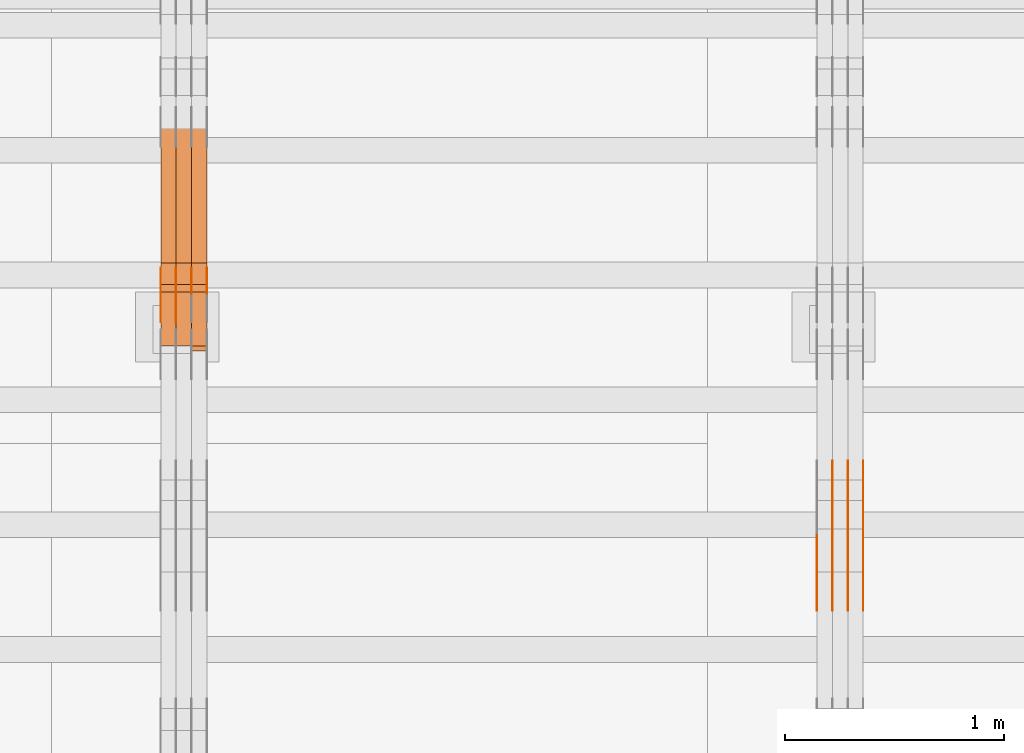
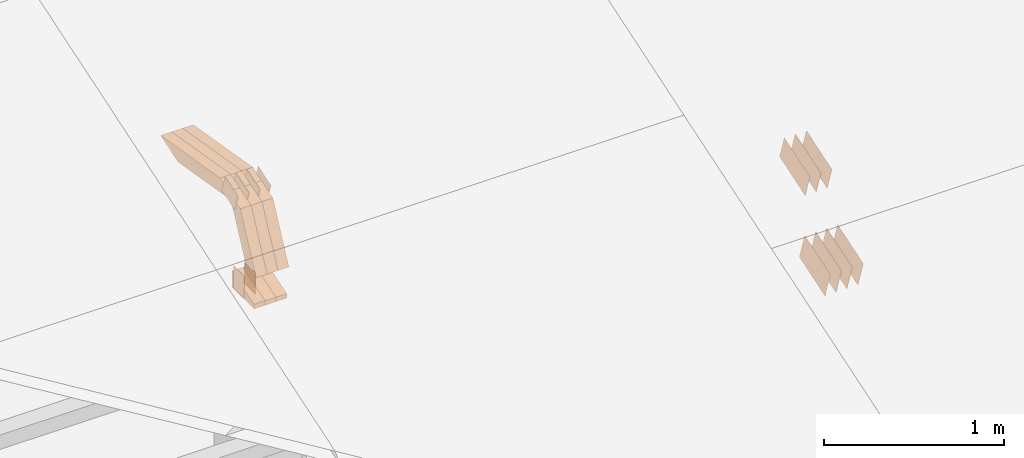
# One storey, part 94 of 385: 28 proxies.
"""IFC2X3 building model written with IfcOpenShell, lengths in millimetres."""

from ifc_helpers import new_model, entity, si_unit, converted_unit, derived_unit, direction, frame, frame_2d, origin, place, context, subcontext, project, spatial, polyline, rectangle, outline, extrude, source, transform, mapped, material, type_object, type_shapes, element, save


model = new_model("IFC2X3")

# Units and contexts
model_context = context("Model", 3, precision=0.01, world=origin(), true_north=direction((6.12303176911189e-17, 1.0)))
body_context = subcontext(model_context, "Body", "Model", "MODEL_VIEW")
ifc_project = project(units=[si_unit("LENGTHUNIT", "METRE", prefix="MILLI"), si_unit("AREAUNIT", "SQUARE_METRE"), si_unit("VOLUMEUNIT", "CUBIC_METRE"), converted_unit("PLANEANGLEUNIT", "DEGREE", entity("IfcRatioMeasure", 0.0174532925199433), si_unit("PLANEANGLEUNIT", "RADIAN"), dimensions=[0, 0, 0, 0, 0, 0, 0]), si_unit("MASSUNIT", "GRAM", prefix="KILO"), derived_unit("MASSDENSITYUNIT", [(si_unit("MASSUNIT", "GRAM", prefix="KILO"), 1), (si_unit("LENGTHUNIT", "METRE"), -3)]), si_unit("TIMEUNIT", "SECOND"), si_unit("FREQUENCYUNIT", "HERTZ"), si_unit("THERMODYNAMICTEMPERATUREUNIT", "DEGREE_CELSIUS"), derived_unit("THERMALTRANSMITTANCEUNIT", [(si_unit("MASSUNIT", "GRAM", prefix="KILO"), 1), (si_unit("THERMODYNAMICTEMPERATUREUNIT", "KELVIN"), -1), (si_unit("TIMEUNIT", "SECOND"), -3)]), derived_unit("VOLUMETRICFLOWRATEUNIT", [(si_unit("LENGTHUNIT", "METRE"), 3), (si_unit("TIMEUNIT", "SECOND"), -1)]), si_unit("ELECTRICCURRENTUNIT", "AMPERE"), si_unit("ELECTRICVOLTAGEUNIT", "VOLT"), si_unit("POWERUNIT", "WATT"), si_unit("FORCEUNIT", "NEWTON", prefix="KILO"), si_unit("ILLUMINANCEUNIT", "LUX"), si_unit("LUMINOUSFLUXUNIT", "LUMEN"), si_unit("LUMINOUSINTENSITYUNIT", "CANDELA"), derived_unit("USERDEFINED", [(si_unit("MASSUNIT", "GRAM", prefix="KILO"), -1), (si_unit("LENGTHUNIT", "METRE"), -2), (si_unit("TIMEUNIT", "SECOND"), 3), (si_unit("LUMINOUSFLUXUNIT", "LUMEN"), 1)]), derived_unit("LINEARVELOCITYUNIT", [(si_unit("LENGTHUNIT", "METRE"), 1), (si_unit("TIMEUNIT", "SECOND"), -1)]), si_unit("PRESSUREUNIT", "PASCAL"), derived_unit("USERDEFINED", [(si_unit("LENGTHUNIT", "METRE"), -2), (si_unit("MASSUNIT", "GRAM", prefix="KILO"), 1), (si_unit("TIMEUNIT", "SECOND"), -2)])], contexts=[model_context])

# Site, building, storey
site_placement = place(None, origin())
site = spatial("IfcSite", under=ifc_project, at=site_placement, CompositionType="ELEMENT")
building_placement = place(site_placement, origin())
building = spatial("IfcBuilding", under=site, at=building_placement, CompositionType="ELEMENT")
storey_placement = place(building_placement, origin())
storey = spatial("IfcBuildingStorey", under=building, at=storey_placement, Name="Default", CompositionType="ELEMENT", Elevation=0.0)

# Proxies
ifc_material_1 = material(Name="IfcSurfaceStyle #208456")
building_element_proxy_type_1 = type_object("IfcBuildingElementProxyType", PredefinedType="NOTDEFINED", material=ifc_material_1)
shared_shape_1 = source(origin(), body_context, "Body", "SweptSolid", [
    extrude(outline(polyline([(-149.99966632326, -95.9999759039407), (149.999881095801, -95.9999759039407), (150.000557367591, 95.9999759039407), (-150.000772140132, 95.9999759039406), (-149.99966632326, -95.9999759039407)])), frame((150.000557367591, 96.0004291135906, 0.0), z_axis=(0.0, 0.0, 1.0), x_axis=(-1.0, 0.0, 0.0)), (0.0, 0.0, 1.0), 1.29999999999999),
])
type_shapes(building_element_proxy_type_1, [shared_shape_1])
proxy_1_placement = place(building_placement, frame((15386.3, 10934.7734375, 2766.8759765625), z_axis=(-1.0, 0.0, 0.0), x_axis=(0.0, 0.951056516295124, 0.309016994375039)))
element("IfcBuildingElementProxy", 1, at=proxy_1_placement, inside=storey, type_object=building_element_proxy_type_1, material=ifc_material_1, context=body_context, shape_type="MappedRepresentation", body=[
    mapped(shared_shape_1, transform((0.0, 0.0, 0.0), scale=1.0)),
])
ifc_material_2 = material(Name="IfcSurfaceStyle #208399")
building_element_proxy_type_2 = type_object("IfcBuildingElementProxyType", PredefinedType="NOTDEFINED", material=ifc_material_2)
shared_shape_2 = source(origin(), body_context, "Body", "SweptSolid", [
    extrude(outline(polyline([(-149.99966632326, -95.9999759039407), (149.999881095801, -95.9999759039407), (150.000557367591, 95.9999759039407), (-150.000772140132, 95.9999759039406), (-149.99966632326, -95.9999759039407)])), frame((150.000557367591, 96.0004291135906, 0.0), z_axis=(0.0, 0.0, 1.0), x_axis=(-1.0, 0.0, 0.0)), (0.0, 0.0, 1.0), 1.29999999999999),
])
type_shapes(building_element_proxy_type_2, [shared_shape_2])
proxy_2_placement = place(building_placement, frame((15315.0, 10934.7734375, 2766.8759765625), z_axis=(-1.0, 0.0, 0.0), x_axis=(0.0, 0.951056516295124, 0.309016994375039)))
element("IfcBuildingElementProxy", 2, at=proxy_2_placement, inside=storey, type_object=building_element_proxy_type_2, material=ifc_material_2, context=body_context, shape_type="MappedRepresentation", body=[
    mapped(shared_shape_2, transform((0.0, 0.0, 0.0), scale=1.0)),
])
ifc_material_3 = material(Name="IfcSurfaceStyle #208342")
building_element_proxy_type_3 = type_object("IfcBuildingElementProxyType", PredefinedType="NOTDEFINED", material=ifc_material_3)
shared_shape_3 = source(origin(), body_context, "Body", "SweptSolid", [
    extrude(outline(polyline([(-149.99966632326, -95.9999759039407), (149.999881095801, -95.9999759039407), (150.000557367591, 95.9999759039407), (-150.000772140132, 95.9999759039406), (-149.99966632326, -95.9999759039407)])), frame((150.000557367591, 96.0004291135906, 0.0), z_axis=(0.0, 0.0, 1.0), x_axis=(-1.0, 0.0, 0.0)), (0.0, 0.0, 1.0), 1.29999999999999),
])
type_shapes(building_element_proxy_type_3, [shared_shape_3])
proxy_3_placement = place(building_placement, frame((15316.3, 10934.7734375, 2766.8759765625), z_axis=(-1.0, 0.0, 0.0), x_axis=(0.0, 0.951056516295124, 0.309016994375039)))
element("IfcBuildingElementProxy", 3, at=proxy_3_placement, inside=storey, type_object=building_element_proxy_type_3, material=ifc_material_3, context=body_context, shape_type="MappedRepresentation", body=[
    mapped(shared_shape_3, transform((0.0, 0.0, 0.0), scale=1.0)),
])
ifc_material_4 = material(Name="IfcSurfaceStyle #208285")
building_element_proxy_type_4 = type_object("IfcBuildingElementProxyType", PredefinedType="NOTDEFINED", material=ifc_material_4)
shared_shape_4 = source(origin(), body_context, "Body", "SweptSolid", [
    extrude(outline(polyline([(-149.99966632326, -95.9999759039407), (149.999881095801, -95.9999759039407), (150.000557367591, 95.9999759039407), (-150.000772140132, 95.9999759039406), (-149.99966632326, -95.9999759039407)])), frame((150.000557367591, 96.0004291135906, 0.0), z_axis=(0.0, 0.0, 1.0), x_axis=(-1.0, 0.0, 0.0)), (0.0, 0.0, 1.0), 1.29999999999998),
])
type_shapes(building_element_proxy_type_4, [shared_shape_4])
proxy_4_placement = place(building_placement, frame((15245.0, 10934.7734375, 2766.8759765625), z_axis=(-1.0, 0.0, 0.0), x_axis=(0.0, 0.951056516295124, 0.309016994375039)))
element("IfcBuildingElementProxy", 4, at=proxy_4_placement, inside=storey, type_object=building_element_proxy_type_4, material=ifc_material_4, context=body_context, shape_type="MappedRepresentation", body=[
    mapped(shared_shape_4, transform((0.0, 0.0, 0.0), scale=1.0)),
])
ifc_material_5 = material(Name="IfcSurfaceStyle #208228")
building_element_proxy_type_5 = type_object("IfcBuildingElementProxyType", PredefinedType="NOTDEFINED", material=ifc_material_5)
shared_shape_5 = source(origin(), body_context, "Body", "SweptSolid", [
    extrude(outline(polyline([(-149.99966632326, -95.9999759039407), (149.999881095801, -95.9999759039407), (150.000557367591, 95.9999759039407), (-150.000772140132, 95.9999759039406), (-149.99966632326, -95.9999759039407)])), frame((150.000557367591, 96.0004291135906, 0.0), z_axis=(0.0, 0.0, 1.0), x_axis=(-1.0, 0.0, 0.0)), (0.0, 0.0, 1.0), 1.29999999999998),
])
type_shapes(building_element_proxy_type_5, [shared_shape_5])
proxy_5_placement = place(building_placement, frame((15246.3, 10934.7734375, 2766.8759765625), z_axis=(-1.0, 0.0, 0.0), x_axis=(0.0, 0.951056516295124, 0.309016994375039)))
element("IfcBuildingElementProxy", 5, at=proxy_5_placement, inside=storey, type_object=building_element_proxy_type_5, material=ifc_material_5, context=body_context, shape_type="MappedRepresentation", body=[
    mapped(shared_shape_5, transform((0.0, 0.0, 0.0), scale=1.0)),
])
ifc_material_6 = material(Name="IfcSurfaceStyle #208171")
building_element_proxy_type_6 = type_object("IfcBuildingElementProxyType", PredefinedType="NOTDEFINED", material=ifc_material_6)
shared_shape_6 = source(origin(), body_context, "Body", "SweptSolid", [
    extrude(outline(polyline([(-149.99966632326, -95.9999759039407), (149.999881095801, -95.9999759039407), (150.000557367591, 95.9999759039407), (-150.000772140132, 95.9999759039406), (-149.99966632326, -95.9999759039407)])), frame((150.000557367591, 96.0004291135906, 0.0), z_axis=(0.0, 0.0, 1.0), x_axis=(-1.0, 0.0, 0.0)), (0.0, 0.0, 1.0), 1.29999999999998),
])
type_shapes(building_element_proxy_type_6, [shared_shape_6])
proxy_6_placement = place(building_placement, frame((15175.0, 10934.7734375, 2766.8759765625), z_axis=(-1.0, 0.0, 0.0), x_axis=(0.0, 0.951056516295124, 0.309016994375039)))
element("IfcBuildingElementProxy", 6, at=proxy_6_placement, inside=storey, type_object=building_element_proxy_type_6, material=ifc_material_6, context=body_context, shape_type="MappedRepresentation", body=[
    mapped(shared_shape_6, transform((0.0, 0.0, 0.0), scale=1.0)),
])
ifc_material_7 = material(Name="IfcSurfaceStyle #198880")
building_element_proxy_type_7 = type_object("IfcBuildingElementProxyType", PredefinedType="NOTDEFINED", material=ifc_material_7)
shared_shape_7 = source(origin(), body_context, "Body", "SweptSolid", [
    extrude(outline(polyline([(-150.000273478628, -84.0002987844282), (149.999198496832, -84.0002987844282), (150.000273478627, 84.0002987844282), (-149.999198496831, 84.0002987844282), (-150.000273478628, -84.0002987844282)])), frame((150.000273478627, 84.0002987844282, 0.0), z_axis=(0.0, 0.0, 1.0), x_axis=(-1.0, 0.0, 0.0)), (0.0, 0.0, 1.0), 1.29999999999999),
])
type_shapes(building_element_proxy_type_7, [shared_shape_7])
proxy_7_placement = place(building_placement, frame((15386.3, 11283.0116722926, 3194.09682266857), z_axis=(-1.0, 0.0, 0.0), x_axis=(0.0, 0.951056516295154, 0.309016994374948)))
element("IfcBuildingElementProxy", 7, at=proxy_7_placement, inside=storey, type_object=building_element_proxy_type_7, material=ifc_material_7, context=body_context, shape_type="MappedRepresentation", body=[
    mapped(shared_shape_7, transform((0.0, 0.0, 0.0), scale=1.0)),
])
ifc_material_8 = material(Name="IfcSurfaceStyle #198823")
building_element_proxy_type_8 = type_object("IfcBuildingElementProxyType", PredefinedType="NOTDEFINED", material=ifc_material_8)
shared_shape_8 = source(origin(), body_context, "Body", "SweptSolid", [
    extrude(outline(polyline([(-150.000273478628, -84.0002987844282), (149.999198496832, -84.0002987844282), (150.000273478627, 84.0002987844282), (-149.999198496831, 84.0002987844282), (-150.000273478628, -84.0002987844282)])), frame((150.000273478627, 84.0002987844282, 0.0), z_axis=(0.0, 0.0, 1.0), x_axis=(-1.0, 0.0, 0.0)), (0.0, 0.0, 1.0), 1.29999999999999),
])
type_shapes(building_element_proxy_type_8, [shared_shape_8])
proxy_8_placement = place(building_placement, frame((15315.0, 11283.0116722926, 3194.09682266857), z_axis=(-1.0, 0.0, 0.0), x_axis=(0.0, 0.951056516295154, 0.309016994374948)))
element("IfcBuildingElementProxy", 8, at=proxy_8_placement, inside=storey, type_object=building_element_proxy_type_8, material=ifc_material_8, context=body_context, shape_type="MappedRepresentation", body=[
    mapped(shared_shape_8, transform((0.0, 0.0, 0.0), scale=1.0)),
])
ifc_material_9 = material(Name="IfcSurfaceStyle #198766")
building_element_proxy_type_9 = type_object("IfcBuildingElementProxyType", PredefinedType="NOTDEFINED", material=ifc_material_9)
shared_shape_9 = source(origin(), body_context, "Body", "SweptSolid", [
    extrude(outline(polyline([(-150.000273478628, -84.0002987844282), (149.999198496832, -84.0002987844282), (150.000273478627, 84.0002987844282), (-149.999198496831, 84.0002987844282), (-150.000273478628, -84.0002987844282)])), frame((150.000273478627, 84.0002987844282, 0.0), z_axis=(0.0, 0.0, 1.0), x_axis=(-1.0, 0.0, 0.0)), (0.0, 0.0, 1.0), 1.29999999999999),
])
type_shapes(building_element_proxy_type_9, [shared_shape_9])
proxy_9_placement = place(building_placement, frame((15316.3, 11283.0116722926, 3194.09682266857), z_axis=(-1.0, 0.0, 0.0), x_axis=(0.0, 0.951056516295154, 0.309016994374948)))
element("IfcBuildingElementProxy", 9, at=proxy_9_placement, inside=storey, type_object=building_element_proxy_type_9, material=ifc_material_9, context=body_context, shape_type="MappedRepresentation", body=[
    mapped(shared_shape_9, transform((0.0, 0.0, 0.0), scale=1.0)),
])
ifc_material_10 = material(Name="IfcSurfaceStyle #198709")
building_element_proxy_type_10 = type_object("IfcBuildingElementProxyType", PredefinedType="NOTDEFINED", material=ifc_material_10)
shared_shape_10 = source(origin(), body_context, "Body", "SweptSolid", [
    extrude(outline(polyline([(-150.000273478628, -84.0002987844282), (149.999198496832, -84.0002987844282), (150.000273478627, 84.0002987844282), (-149.999198496831, 84.0002987844282), (-150.000273478628, -84.0002987844282)])), frame((150.000273478627, 84.0002987844282, 0.0), z_axis=(0.0, 0.0, 1.0), x_axis=(-1.0, 0.0, 0.0)), (0.0, 0.0, 1.0), 1.29999999999998),
])
type_shapes(building_element_proxy_type_10, [shared_shape_10])
proxy_10_placement = place(building_placement, frame((15245.0, 11283.0116722926, 3194.09682266857), z_axis=(-1.0, 0.0, 0.0), x_axis=(0.0, 0.951056516295154, 0.309016994374948)))
element("IfcBuildingElementProxy", 10, at=proxy_10_placement, inside=storey, type_object=building_element_proxy_type_10, material=ifc_material_10, context=body_context, shape_type="MappedRepresentation", body=[
    mapped(shared_shape_10, transform((0.0, 0.0, 0.0), scale=1.0)),
])
ifc_material_11 = material(Name="IfcSurfaceStyle #172143")
building_element_proxy_type_11 = type_object("IfcBuildingElementProxyType", PredefinedType="NOTDEFINED", material=ifc_material_11)
shared_shape_11 = source(origin(), body_context, "Body", "SweptSolid", [
    extrude(rectangle(XDim=150.0, YDim=119.999999999985, at=frame_2d((-7.105427357601e-15, 0.0), x_axis=(1.0, 0.0))), frame((75.0, 60.0, 0.0), z_axis=(0.0, 0.0, 1.0), x_axis=(-1.0, 0.0, 0.0)), (0.0, 0.0, 1.0), 1.29999999999999),
])
type_shapes(building_element_proxy_type_11, [shared_shape_11])
proxy_11_placement = place(building_placement, frame((12245.0, 12372.95703125, 3007.04687500001), z_axis=(-1.0, 0.0, 0.0), x_axis=(0.0, 0.0, -1.0)))
element("IfcBuildingElementProxy", 11, at=proxy_11_placement, inside=storey, type_object=building_element_proxy_type_11, material=ifc_material_11, context=body_context, shape_type="MappedRepresentation", body=[
    mapped(shared_shape_11, transform((0.0, 0.0, 0.0), scale=1.0)),
])
ifc_material_12 = material(Name="IfcSurfaceStyle #172086")
building_element_proxy_type_12 = type_object("IfcBuildingElementProxyType", PredefinedType="NOTDEFINED", material=ifc_material_12)
shared_shape_12 = source(origin(), body_context, "Body", "SweptSolid", [
    extrude(rectangle(XDim=150.0, YDim=119.999999999985, at=frame_2d((-7.105427357601e-15, 0.0), x_axis=(1.0, 0.0))), frame((75.0, 60.0, 0.0), z_axis=(0.0, 0.0, 1.0), x_axis=(-1.0, 0.0, 0.0)), (0.0, 0.0, 1.0), 1.29999999999999),
])
type_shapes(building_element_proxy_type_12, [shared_shape_12])
proxy_12_placement = place(building_placement, frame((12246.3, 12372.95703125, 3007.04687500001), z_axis=(-1.0, 0.0, 0.0), x_axis=(0.0, 0.0, -1.0)))
element("IfcBuildingElementProxy", 12, at=proxy_12_placement, inside=storey, type_object=building_element_proxy_type_12, material=ifc_material_12, context=body_context, shape_type="MappedRepresentation", body=[
    mapped(shared_shape_12, transform((0.0, 0.0, 0.0), scale=1.0)),
])
ifc_material_13 = material(Name="IfcSurfaceStyle #172029")
building_element_proxy_type_13 = type_object("IfcBuildingElementProxyType", PredefinedType="NOTDEFINED", material=ifc_material_13)
shared_shape_13 = source(origin(), body_context, "Body", "SweptSolid", [
    extrude(rectangle(XDim=150.0, YDim=119.999999999985, at=frame_2d((-7.105427357601e-15, 0.0), x_axis=(1.0, 0.0))), frame((75.0, 60.0, 0.0), z_axis=(0.0, 0.0, 1.0), x_axis=(-1.0, 0.0, 0.0)), (0.0, 0.0, 1.0), 1.29999999999999),
])
type_shapes(building_element_proxy_type_13, [shared_shape_13])
proxy_13_placement = place(building_placement, frame((12175.0, 12372.95703125, 3007.04687500001), z_axis=(-1.0, 0.0, 0.0), x_axis=(0.0, 0.0, -1.0)))
element("IfcBuildingElementProxy", 13, at=proxy_13_placement, inside=storey, type_object=building_element_proxy_type_13, material=ifc_material_13, context=body_context, shape_type="MappedRepresentation", body=[
    mapped(shared_shape_13, transform((0.0, 0.0, 0.0), scale=1.0)),
])
ifc_material_14 = material(Name="IfcSurfaceStyle #165132")
building_element_proxy_type_14 = type_object("IfcBuildingElementProxyType", PredefinedType="NOTDEFINED", material=ifc_material_14)
shared_shape_14 = source(origin(), body_context, "Body", "SweptSolid", [
    extrude(outline(polyline([(-74.9998754286244, -60.0000016373506), (74.9998605591063, -60.0000016373506), (74.9998754286244, 60.0000016373506), (-74.9998605591063, 60.0000016373506), (-74.9998754286244, -60.0000016373506)])), frame((74.9998754286244, 60.0000016373506, 0.0), z_axis=(0.0, 0.0, 1.0), x_axis=(-1.0, 0.0, 0.0)), (0.0, 0.0, 1.0), 1.3),
])
type_shapes(building_element_proxy_type_14, [shared_shape_14])
proxy_14_placement = place(building_placement, frame((12386.3, 12321.1620861463, 3506.17707344366), z_axis=(-1.0, 0.0, 0.0), x_axis=(0.0, 0.951056516295154, 0.309016994374948)))
element("IfcBuildingElementProxy", 14, at=proxy_14_placement, inside=storey, type_object=building_element_proxy_type_14, material=ifc_material_14, context=body_context, shape_type="MappedRepresentation", body=[
    mapped(shared_shape_14, transform((0.0, 0.0, 0.0), scale=1.0)),
])
ifc_material_15 = material(Name="IfcSurfaceStyle #165075")
building_element_proxy_type_15 = type_object("IfcBuildingElementProxyType", PredefinedType="NOTDEFINED", material=ifc_material_15)
shared_shape_15 = source(origin(), body_context, "Body", "SweptSolid", [
    extrude(outline(polyline([(-74.9998754286244, -60.0000016373506), (74.9998605591063, -60.0000016373506), (74.9998754286244, 60.0000016373506), (-74.9998605591063, 60.0000016373506), (-74.9998754286244, -60.0000016373506)])), frame((74.9998754286244, 60.0000016373506, 0.0), z_axis=(0.0, 0.0, 1.0), x_axis=(-1.0, 0.0, 0.0)), (0.0, 0.0, 1.0), 1.3),
])
type_shapes(building_element_proxy_type_15, [shared_shape_15])
proxy_15_placement = place(building_placement, frame((12315.0, 12321.1620861463, 3506.17707344366), z_axis=(-1.0, 0.0, 0.0), x_axis=(0.0, 0.951056516295154, 0.309016994374948)))
element("IfcBuildingElementProxy", 15, at=proxy_15_placement, inside=storey, type_object=building_element_proxy_type_15, material=ifc_material_15, context=body_context, shape_type="MappedRepresentation", body=[
    mapped(shared_shape_15, transform((0.0, 0.0, 0.0), scale=1.0)),
])
ifc_material_16 = material(Name="IfcSurfaceStyle #165018")
building_element_proxy_type_16 = type_object("IfcBuildingElementProxyType", PredefinedType="NOTDEFINED", material=ifc_material_16)
shared_shape_16 = source(origin(), body_context, "Body", "SweptSolid", [
    extrude(outline(polyline([(-74.9998754286244, -60.0000016373506), (74.9998605591063, -60.0000016373506), (74.9998754286244, 60.0000016373506), (-74.9998605591063, 60.0000016373506), (-74.9998754286244, -60.0000016373506)])), frame((74.9998754286244, 60.0000016373506, 0.0), z_axis=(0.0, 0.0, 1.0), x_axis=(-1.0, 0.0, 0.0)), (0.0, 0.0, 1.0), 1.3),
])
type_shapes(building_element_proxy_type_16, [shared_shape_16])
proxy_16_placement = place(building_placement, frame((12316.3, 12321.1620861463, 3506.17707344366), z_axis=(-1.0, 0.0, 0.0), x_axis=(0.0, 0.951056516295154, 0.309016994374948)))
element("IfcBuildingElementProxy", 16, at=proxy_16_placement, inside=storey, type_object=building_element_proxy_type_16, material=ifc_material_16, context=body_context, shape_type="MappedRepresentation", body=[
    mapped(shared_shape_16, transform((0.0, 0.0, 0.0), scale=1.0)),
])
ifc_material_17 = material(Name="IfcSurfaceStyle #164961")
building_element_proxy_type_17 = type_object("IfcBuildingElementProxyType", PredefinedType="NOTDEFINED", material=ifc_material_17)
shared_shape_17 = source(origin(), body_context, "Body", "SweptSolid", [
    extrude(outline(polyline([(-74.9998754286244, -60.0000016373506), (74.9998605591063, -60.0000016373506), (74.9998754286244, 60.0000016373506), (-74.9998605591063, 60.0000016373506), (-74.9998754286244, -60.0000016373506)])), frame((74.9998754286244, 60.0000016373506, 0.0), z_axis=(0.0, 0.0, 1.0), x_axis=(-1.0, 0.0, 0.0)), (0.0, 0.0, 1.0), 1.29999999999999),
])
type_shapes(building_element_proxy_type_17, [shared_shape_17])
proxy_17_placement = place(building_placement, frame((12245.0, 12321.1620861463, 3506.17707344366), z_axis=(-1.0, 0.0, 0.0), x_axis=(0.0, 0.951056516295154, 0.309016994374948)))
element("IfcBuildingElementProxy", 17, at=proxy_17_placement, inside=storey, type_object=building_element_proxy_type_17, material=ifc_material_17, context=body_context, shape_type="MappedRepresentation", body=[
    mapped(shared_shape_17, transform((0.0, 0.0, 0.0), scale=1.0)),
])
ifc_material_18 = material(Name="IfcSurfaceStyle #164904")
building_element_proxy_type_18 = type_object("IfcBuildingElementProxyType", PredefinedType="NOTDEFINED", material=ifc_material_18)
shared_shape_18 = source(origin(), body_context, "Body", "SweptSolid", [
    extrude(outline(polyline([(-74.9998754286244, -60.0000016373506), (74.9998605591063, -60.0000016373506), (74.9998754286244, 60.0000016373506), (-74.9998605591063, 60.0000016373506), (-74.9998754286244, -60.0000016373506)])), frame((74.9998754286244, 60.0000016373506, 0.0), z_axis=(0.0, 0.0, 1.0), x_axis=(-1.0, 0.0, 0.0)), (0.0, 0.0, 1.0), 1.29999999999999),
])
type_shapes(building_element_proxy_type_18, [shared_shape_18])
proxy_18_placement = place(building_placement, frame((12246.3, 12321.1620861463, 3506.17707344366), z_axis=(-1.0, 0.0, 0.0), x_axis=(0.0, 0.951056516295154, 0.309016994374948)))
element("IfcBuildingElementProxy", 18, at=proxy_18_placement, inside=storey, type_object=building_element_proxy_type_18, material=ifc_material_18, context=body_context, shape_type="MappedRepresentation", body=[
    mapped(shared_shape_18, transform((0.0, 0.0, 0.0), scale=1.0)),
])
ifc_material_19 = material(Name="IfcSurfaceStyle #164847")
building_element_proxy_type_19 = type_object("IfcBuildingElementProxyType", PredefinedType="NOTDEFINED", material=ifc_material_19)
shared_shape_19 = source(origin(), body_context, "Body", "SweptSolid", [
    extrude(outline(polyline([(-74.9998754286244, -60.0000016373506), (74.9998605591063, -60.0000016373506), (74.9998754286244, 60.0000016373506), (-74.9998605591063, 60.0000016373506), (-74.9998754286244, -60.0000016373506)])), frame((74.9998754286244, 60.0000016373506, 0.0), z_axis=(0.0, 0.0, 1.0), x_axis=(-1.0, 0.0, 0.0)), (0.0, 0.0, 1.0), 1.29999999999999),
])
type_shapes(building_element_proxy_type_19, [shared_shape_19])
proxy_19_placement = place(building_placement, frame((12175.0, 12321.1620861463, 3506.17707344366), z_axis=(-1.0, 0.0, 0.0), x_axis=(0.0, 0.951056516295154, 0.309016994374948)))
element("IfcBuildingElementProxy", 19, at=proxy_19_placement, inside=storey, type_object=building_element_proxy_type_19, material=ifc_material_19, context=body_context, shape_type="MappedRepresentation", body=[
    mapped(shared_shape_19, transform((0.0, 0.0, 0.0), scale=1.0)),
])
ifc_material_20 = material(Name="IfcSurfaceStyle #156672")
building_element_proxy_type_20 = type_object("IfcBuildingElementProxyType", Name="T1-E1 156670", PredefinedType="NOTDEFINED", material=ifc_material_20)
shared_shape_20 = source(origin(), body_context, "Body", "SweptSolid", [
    extrude(outline(polyline([(-75.1378173828004, -122.500000000005), (35.3350830078246, -122.500000000005), (35.3350830078004, 122.500000000005), (4.46765136717545, 122.500000000005), (-75.1378173828004, -122.500000000005)])), frame((35.3350830078246, 122.500000104877, 0.0), z_axis=(0.0, 0.0, 1.0), x_axis=(-1.0, 0.0, 0.0)), (0.0, 0.0, 1.0), 70.0),
])
type_shapes(building_element_proxy_type_20, [shared_shape_20])
proxy_20_placement = place(building_placement, frame((12385.0, 12145.0, 2849.54565429685), z_axis=(-1.0, 0.0, 0.0), x_axis=(0.0, 0.0, 1.0)))
element("IfcBuildingElementProxy", 20, at=proxy_20_placement, inside=storey, type_object=building_element_proxy_type_20, material=ifc_material_20, Name="T1-E1", context=body_context, shape_type="MappedRepresentation", body=[
    mapped(shared_shape_20, transform((0.0, 0.0, 0.0), scale=1.0)),
])
ifc_material_21 = material(Name="IfcSurfaceStyle #156615")
building_element_proxy_type_21 = type_object("IfcBuildingElementProxyType", Name="T1-E1 156613", PredefinedType="NOTDEFINED", material=ifc_material_21)
shared_shape_21 = source(origin(), body_context, "Body", "SweptSolid", [
    extrude(outline(polyline([(-75.1378173828004, -122.500000000005), (35.3350830078246, -122.500000000005), (35.3350830078004, 122.500000000005), (4.46765136717545, 122.500000000005), (-75.1378173828004, -122.500000000005)])), frame((35.3350830078246, 122.500000104877, 0.0), z_axis=(0.0, 0.0, 1.0), x_axis=(-1.0, 0.0, 0.0)), (0.0, 0.0, 1.0), 70.0),
])
type_shapes(building_element_proxy_type_21, [shared_shape_21])
proxy_21_placement = place(building_placement, frame((12315.0, 12145.0, 2849.54565429685), z_axis=(-1.0, 0.0, 0.0), x_axis=(0.0, 0.0, 1.0)))
element("IfcBuildingElementProxy", 21, at=proxy_21_placement, inside=storey, type_object=building_element_proxy_type_21, material=ifc_material_21, Name="T1-E1", context=body_context, shape_type="MappedRepresentation", body=[
    mapped(shared_shape_21, transform((0.0, 0.0, 0.0), scale=1.0)),
])
ifc_material_22 = material(Name="IfcSurfaceStyle #156558")
building_element_proxy_type_22 = type_object("IfcBuildingElementProxyType", Name="T1-E1 156556", PredefinedType="NOTDEFINED", material=ifc_material_22)
shared_shape_22 = source(origin(), body_context, "Body", "SweptSolid", [
    extrude(outline(polyline([(-75.1378173828004, -122.500000000005), (35.3350830078246, -122.500000000005), (35.3350830078004, 122.500000000005), (4.46765136717545, 122.500000000005), (-75.1378173828004, -122.500000000005)])), frame((35.3350830078246, 122.500000104877, 0.0), z_axis=(0.0, 0.0, 1.0), x_axis=(-1.0, 0.0, 0.0)), (0.0, 0.0, 1.0), 70.0),
])
type_shapes(building_element_proxy_type_22, [shared_shape_22])
proxy_22_placement = place(building_placement, frame((12245.0, 12145.0, 2849.54565429685), z_axis=(-1.0, 0.0, 0.0), x_axis=(0.0, 0.0, 1.0)))
element("IfcBuildingElementProxy", 22, at=proxy_22_placement, inside=storey, type_object=building_element_proxy_type_22, material=ifc_material_22, Name="T1-E1", context=body_context, shape_type="MappedRepresentation", body=[
    mapped(shared_shape_22, transform((0.0, 0.0, 0.0), scale=1.0)),
])
ifc_material_23 = material(Name="IfcSurfaceStyle #154944")
building_element_proxy_type_23 = type_object("IfcBuildingElementProxyType", Name="T1-W7 154942", PredefinedType="NOTDEFINED", material=ifc_material_23)
shared_shape_23 = source(origin(), body_context, "Body", "SweptSolid", [
    extrude(outline(polyline([(-296.174043820986, -47.5000676566704), (297.841254477443, -47.5000676566704), (283.518570346415, -7.10254316533821e-06), (192.674144473719, 47.500071207942), (-477.859925476591, 47.500071207942), (-296.174043820986, -47.5000676566704)])), frame((297.841254477443, 47.5000816097442, 0.0), z_axis=(0.0, 0.0, 1.0), x_axis=(-1.0, 0.0, 0.0)), (0.0, 0.0, 1.0), 70.0),
])
type_shapes(building_element_proxy_type_23, [shared_shape_23])
proxy_23_placement = place(building_placement, frame((12385.0, 12419.2991208897, 3526.2136755972), z_axis=(-1.0, 0.0, 0.0), x_axis=(0.0, 0.985983815111804, -0.166840991178939)))
element("IfcBuildingElementProxy", 23, at=proxy_23_placement, inside=storey, type_object=building_element_proxy_type_23, material=ifc_material_23, Name="T1-W7", context=body_context, shape_type="MappedRepresentation", body=[
    mapped(shared_shape_23, transform((0.0, 0.0, 0.0), scale=1.0)),
])
ifc_material_24 = material(Name="IfcSurfaceStyle #154878")
building_element_proxy_type_24 = type_object("IfcBuildingElementProxyType", Name="T1-W7 154876", PredefinedType="NOTDEFINED", material=ifc_material_24)
shared_shape_24 = source(origin(), body_context, "Body", "SweptSolid", [
    extrude(outline(polyline([(-296.174043820986, -47.5000676566704), (297.841254477443, -47.5000676566704), (283.518570346415, -7.10254316533821e-06), (192.674144473719, 47.500071207942), (-477.859925476591, 47.500071207942), (-296.174043820986, -47.5000676566704)])), frame((297.841254477443, 47.5000816097442, 0.0), z_axis=(0.0, 0.0, 1.0), x_axis=(-1.0, 0.0, 0.0)), (0.0, 0.0, 1.0), 70.0),
])
type_shapes(building_element_proxy_type_24, [shared_shape_24])
proxy_24_placement = place(building_placement, frame((12315.0, 12419.2991208897, 3526.2136755972), z_axis=(-1.0, 0.0, 0.0), x_axis=(0.0, 0.985983815111804, -0.166840991178939)))
element("IfcBuildingElementProxy", 24, at=proxy_24_placement, inside=storey, type_object=building_element_proxy_type_24, material=ifc_material_24, Name="T1-W7", context=body_context, shape_type="MappedRepresentation", body=[
    mapped(shared_shape_24, transform((0.0, 0.0, 0.0), scale=1.0)),
])
ifc_material_25 = material(Name="IfcSurfaceStyle #154812")
building_element_proxy_type_25 = type_object("IfcBuildingElementProxyType", Name="T1-W7 154810", PredefinedType="NOTDEFINED", material=ifc_material_25)
shared_shape_25 = source(origin(), body_context, "Body", "SweptSolid", [
    extrude(outline(polyline([(-296.174043820986, -47.5000676566704), (297.841254477443, -47.5000676566704), (283.518570346415, -7.10254316533821e-06), (192.674144473719, 47.500071207942), (-477.859925476591, 47.500071207942), (-296.174043820986, -47.5000676566704)])), frame((297.841254477443, 47.5000816097442, 0.0), z_axis=(0.0, 0.0, 1.0), x_axis=(-1.0, 0.0, 0.0)), (0.0, 0.0, 1.0), 70.0),
])
type_shapes(building_element_proxy_type_25, [shared_shape_25])
proxy_25_placement = place(building_placement, frame((12245.0, 12419.2991208897, 3526.2136755972), z_axis=(-1.0, 0.0, 0.0), x_axis=(0.0, 0.985983815111804, -0.166840991178939)))
element("IfcBuildingElementProxy", 25, at=proxy_25_placement, inside=storey, type_object=building_element_proxy_type_25, material=ifc_material_25, Name="T1-W7", context=body_context, shape_type="MappedRepresentation", body=[
    mapped(shared_shape_25, transform((0.0, 0.0, 0.0), scale=1.0)),
])
ifc_material_26 = material(Name="IfcSurfaceStyle #154548")
building_element_proxy_type_26 = type_object("IfcBuildingElementProxyType", Name="T1-W36 154546", PredefinedType="NOTDEFINED", material=ifc_material_26)
shared_shape_26 = source(origin(), body_context, "Body", "SweptSolid", [
    extrude(outline(polyline([(-300.714670922549, -47.4998881108849), (134.031527004269, -47.499888110885), (180.52054953879, -0.000136170977331764), (193.89900152221, 47.500563476126), (-207.736407142719, 47.4993489166213), (-300.714670922549, -47.4998881108849)])), frame((193.899145164686, 47.5001861375837, 0.0), z_axis=(0.0, 0.0, 1.0), x_axis=(-1.0, 3.02403492980632e-06, 0.0)), (0.0, 0.0, 1.0), 70.0),
])
type_shapes(building_element_proxy_type_26, [shared_shape_26])
proxy_26_placement = place(building_placement, frame((12385.0, 12120.5935627532, 3076.1128858536), z_axis=(-1.0, 0.0, 0.0), x_axis=(0.0, 0.444384650266842, 0.895836080210669)))
element("IfcBuildingElementProxy", 26, at=proxy_26_placement, inside=storey, type_object=building_element_proxy_type_26, material=ifc_material_26, Name="T1-W36", context=body_context, shape_type="MappedRepresentation", body=[
    mapped(shared_shape_26, transform((0.0, 0.0, 0.0), scale=1.0)),
])
ifc_material_27 = material(Name="IfcSurfaceStyle #154482")
building_element_proxy_type_27 = type_object("IfcBuildingElementProxyType", Name="T1-W36 154480", PredefinedType="NOTDEFINED", material=ifc_material_27)
shared_shape_27 = source(origin(), body_context, "Body", "SweptSolid", [
    extrude(outline(polyline([(-300.714670922549, -47.4998881108849), (134.031527004269, -47.499888110885), (180.52054953879, -0.000136170977331764), (193.89900152221, 47.500563476126), (-207.736407142719, 47.4993489166213), (-300.714670922549, -47.4998881108849)])), frame((193.899145164686, 47.5001861375837, 0.0), z_axis=(0.0, 0.0, 1.0), x_axis=(-1.0, 3.02403492980632e-06, 0.0)), (0.0, 0.0, 1.0), 70.0),
])
type_shapes(building_element_proxy_type_27, [shared_shape_27])
proxy_27_placement = place(building_placement, frame((12315.0, 12120.5935627532, 3076.1128858536), z_axis=(-1.0, 0.0, 0.0), x_axis=(0.0, 0.444384650266842, 0.895836080210669)))
element("IfcBuildingElementProxy", 27, at=proxy_27_placement, inside=storey, type_object=building_element_proxy_type_27, material=ifc_material_27, Name="T1-W36", context=body_context, shape_type="MappedRepresentation", body=[
    mapped(shared_shape_27, transform((0.0, 0.0, 0.0), scale=1.0)),
])
ifc_material_28 = material(Name="IfcSurfaceStyle #154416")
building_element_proxy_type_28 = type_object("IfcBuildingElementProxyType", Name="T1-W36 154414", PredefinedType="NOTDEFINED", material=ifc_material_28)
shared_shape_28 = source(origin(), body_context, "Body", "SweptSolid", [
    extrude(outline(polyline([(-300.714670922549, -47.4998881108849), (134.031527004269, -47.499888110885), (180.52054953879, -0.000136170977331764), (193.89900152221, 47.500563476126), (-207.736407142719, 47.4993489166213), (-300.714670922549, -47.4998881108849)])), frame((193.899145164686, 47.5001861375837, 0.0), z_axis=(0.0, 0.0, 1.0), x_axis=(-1.0, 3.02403492980632e-06, 0.0)), (0.0, 0.0, 1.0), 70.0),
])
type_shapes(building_element_proxy_type_28, [shared_shape_28])
proxy_28_placement = place(building_placement, frame((12245.0, 12120.5935627532, 3076.1128858536), z_axis=(-1.0, 0.0, 0.0), x_axis=(0.0, 0.444384650266842, 0.895836080210669)))
element("IfcBuildingElementProxy", 28, at=proxy_28_placement, inside=storey, type_object=building_element_proxy_type_28, material=ifc_material_28, Name="T1-W36", context=body_context, shape_type="MappedRepresentation", body=[
    mapped(shared_shape_28, transform((0.0, 0.0, 0.0), scale=1.0)),
])

save(model, "model.ifc")
